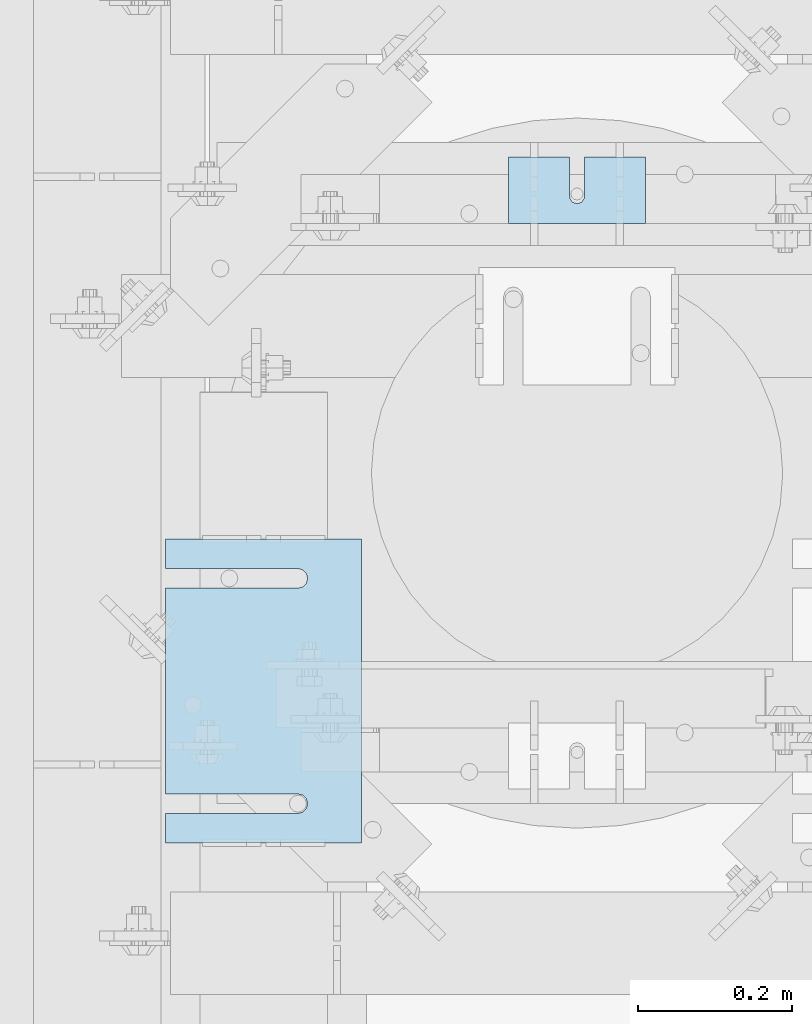
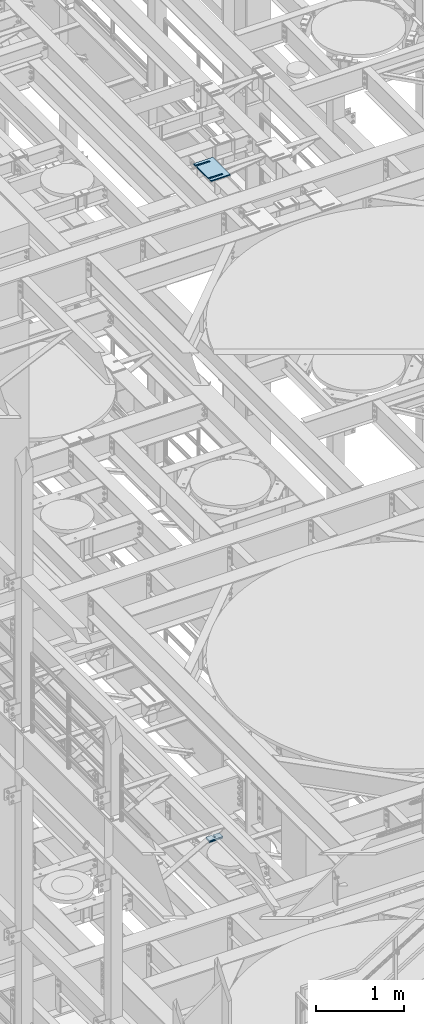
# One storey, part 1636 of 1876: 11 plates, 11 elements without a shape of their own.
"""IFC2X3 building model written with IfcOpenShell, lengths in millimetres."""

from ifc_helpers import new_model, si_unit, frame, origin_with_axes, place, context, subcontext, project, spatial, faceted_brep, material, type_object, element, aggregate, save


model = new_model("IFC2X3")

# Units and contexts
model_context = context("Model", 3, precision=1e-05, world=origin_with_axes())
body_context = subcontext(model_context, "Body", "Model", "MODEL_VIEW")
ifc_project = project(units=[si_unit("LENGTHUNIT", "METRE", prefix="MILLI"), si_unit("AREAUNIT", "SQUARE_METRE"), si_unit("VOLUMEUNIT", "CUBIC_METRE"), si_unit("MASSUNIT", "GRAM", prefix="KILO"), si_unit("TIMEUNIT", "SECOND"), si_unit("PLANEANGLEUNIT", "RADIAN"), si_unit("SOLIDANGLEUNIT", "STERADIAN"), si_unit("THERMODYNAMICTEMPERATUREUNIT", "DEGREE_CELSIUS"), si_unit("LUMINOUSINTENSITYUNIT", "LUMEN")], contexts=[model_context])

# Site, building, storey
site_placement = place(None, origin_with_axes())
site = spatial("IfcSite", under=ifc_project, at=site_placement, CompositionType="ELEMENT")
building_placement = place(site_placement, origin_with_axes())
building = spatial("IfcBuilding", under=site, at=building_placement, Name="Undefined", CompositionType="ELEMENT")
storey_placement = place(building_placement, origin_with_axes())
storey = spatial("IfcBuildingStorey", under=building, at=storey_placement, Name="Undefined", CompositionType="ELEMENT", Elevation=0.0)

# Assembly, plate
assembly_1_placement = place(storey_placement, origin_with_axes())
assembly_1 = element("IfcElementAssembly", 1, at=assembly_1_placement, inside=storey, Name="SHIM PLATE", AssemblyPlace="NOTDEFINED", PredefinedType="RIGID_FRAME")
ifc_material = material(Name="STEEL/A36")
plate_type_1 = type_object("IfcPlateType", PredefinedType="NOTDEFINED")
plate_1_placement = place(assembly_1_placement, frame((4508.50086692662, 2765.42767333984, 8158.1635), z_axis=(0.0, 1.0, 0.0), x_axis=(-1.0, 0.0, 0.0)))
plate_1 = element("IfcPlate", 2, at=plate_1_placement, type_object=plate_type_1, material=ifc_material, Name="SHIM PLATE", context=body_context, shape_type="Brep", body=[
    faceted_brep([(79.3754980174272, -4.76249999999982, 85.7959442138672), (79.3816870943956, -4.76249999999982, 38.1942513122049), (79.3816870943956, 4.76249999999982, 38.1942513122049), (79.3754980174272, 4.76249999999982, 85.7959442138672), (79.5339603115162, -4.76249999999982, 32.1592455981272), (79.5339603115162, 4.76249999999982, 32.1592455981272), (83.1558903074947, -4.76249999999982, 27.3295350264834), (83.1558903074947, 4.76249999999982, 27.3295350264834), (88.9066875296403, -4.76249999999982, 25.4930132021109), (88.9066875296403, 4.76249999999982, 25.4930132021109), (94.6574845388659, -4.76249999999982, 27.3295356932131), (94.6574845388659, 4.76249999999982, 27.3295356932131), (98.2794139749021, -4.76249999999982, 32.1592466847724), (98.2794139749021, 4.76249999999982, 32.1592466847724), (98.4316864923421, -4.76249999999982, 38.1942524165047), (98.4316864923421, 4.76249999999982, 38.1942524165047), (98.4254974155128, -4.76249999999982, 85.7959442138635), (98.4254974155128, 4.76249999999982, 85.7959442138672), (0.0, -4.76249999999982, 0.0), (0.0, -4.76249999999982, 85.7959442138672), (0.0, 4.76249999999982, 85.7959442138672), (0.0, 4.76249999999982, 0.0), (177.800994873047, -4.76249999999982, 0.0), (177.800994873047, 4.76249999999982, 0.0), (177.800994873047, -4.76249999999982, 85.7959442138672), (177.800994873047, 4.76249999999982, 85.7959442138672)], [[[0, 1, 2, 3]], [[4, 5, 2, 1]], [[6, 7, 5, 4]], [[8, 9, 7, 6]], [[10, 11, 9, 8]], [[12, 13, 11, 10]], [[14, 15, 13, 12]], [[16, 17, 15, 14]], [[18, 19, 20, 21]], [[22, 18, 21, 23]], [[24, 22, 23, 25]], [[12, 10, 8, 6, 4, 1, 0, 19, 18, 22, 24, 16, 14]], [[20, 19, 0, 3]], [[25, 23, 21, 20, 3, 2, 5, 7, 9, 11, 13, 15, 17]], [[24, 25, 17, 16]]]),
])
aggregate(assembly_1, [plate_1])

assembly_2_placement = place(storey_placement, origin_with_axes())
assembly_2 = element("IfcElementAssembly", 3, at=assembly_2_placement, inside=storey, Name="SHIM PLATE", AssemblyPlace="NOTDEFINED", PredefinedType="RIGID_FRAME")
plate_type_2 = type_object("IfcPlateType", PredefinedType="NOTDEFINED")
plate_2_placement = place(assembly_2_placement, frame((4508.50086692662, 2765.42767333984, 8179.5935), z_axis=(0.0, 1.0, 0.0), x_axis=(-1.0, 0.0, 0.0)))
plate_2 = element("IfcPlate", 4, at=plate_2_placement, type_object=plate_type_2, material=ifc_material, Name="SHIM PLATE", context=body_context, shape_type="Brep", body=[
    faceted_brep([(79.3754980174272, -0.793499999999767, 85.7959442138672), (79.3816870943956, -0.793499999999767, 38.1942513122049), (79.3816870943956, 0.793499999999767, 38.1942513122049), (79.3754980174272, 0.793499999999767, 85.7959442138672), (79.5339603115162, -0.793499999999767, 32.1592455981272), (79.5339603115162, 0.793499999999767, 32.1592455981272), (83.1558903074947, -0.793499999999767, 27.3295350264834), (83.1558903074947, 0.793499999999767, 27.3295350264834), (88.9066875296403, -0.793499999999767, 25.4930132021109), (88.9066875296403, 0.793499999999767, 25.4930132021109), (94.6574845388659, -0.793499999999767, 27.3295356932131), (94.6574845388659, 0.793499999999767, 27.3295356932131), (98.2794139749021, -0.793499999999767, 32.1592466847724), (98.2794139749021, 0.793499999999767, 32.1592466847724), (98.4316864923421, -0.793499999999767, 38.1942524165047), (98.4316864923421, 0.793499999999767, 38.1942524165047), (98.4254974155128, -0.793499999999767, 85.7959442138635), (98.4254974155128, 0.793499999999767, 85.7959442138672), (9.09494701772928e-13, -0.793499999999767, 0.0), (0.0, -0.793499999999767, 85.7959442138672), (0.0, 0.793499999999767, 85.7959442138672), (9.09494701772928e-13, 0.793499999999767, 0.0), (177.800994873047, -0.793499999999767, 0.0), (177.800994873047, 0.793499999999767, 0.0), (177.800994873047, -0.793499999999767, 85.7959442138672), (177.800994873047, 0.793499999999767, 85.7959442138672)], [[[0, 1, 2, 3]], [[4, 5, 2, 1]], [[6, 7, 5, 4]], [[8, 9, 7, 6]], [[10, 11, 9, 8]], [[12, 13, 11, 10]], [[14, 15, 13, 12]], [[16, 17, 15, 14]], [[18, 19, 20, 21]], [[22, 18, 21, 23]], [[24, 22, 23, 25]], [[12, 10, 8, 6, 4, 1, 0, 19, 18, 22, 24, 16, 14]], [[20, 19, 0, 3]], [[25, 23, 21, 20, 3, 2, 5, 7, 9, 11, 13, 15, 17]], [[24, 25, 17, 16]]]),
])
aggregate(assembly_2, [plate_2])

assembly_3_placement = place(storey_placement, origin_with_axes())
assembly_3 = element("IfcElementAssembly", 5, at=assembly_3_placement, inside=storey, Name="SHIM PLATE", AssemblyPlace="NOTDEFINED", PredefinedType="RIGID_FRAME")
plate_type_3 = type_object("IfcPlateType", PredefinedType="NOTDEFINED")
plate_3_placement = place(assembly_3_placement, frame((4508.50086692662, 2765.42767333984, 8177.2125), z_axis=(0.0, 1.0, 0.0), x_axis=(-1.0, 0.0, 0.0)))
plate_3 = element("IfcPlate", 6, at=plate_3_placement, type_object=plate_type_3, material=ifc_material, Name="SHIM PLATE", context=body_context, shape_type="Brep", body=[
    faceted_brep([(79.3754980174272, -1.58749999999964, 85.7959442138672), (79.3816870943956, -1.58749999999964, 38.1942513122049), (79.3816870943956, 1.58749999999964, 38.1942513122049), (79.3754980174272, 1.58749999999964, 85.7959442138672), (79.5339603115162, -1.58749999999964, 32.1592455981272), (79.5339603115162, 1.58749999999964, 32.1592455981272), (83.1558903074947, -1.58749999999964, 27.3295350264834), (83.1558903074947, 1.58749999999964, 27.3295350264834), (88.9066875296403, -1.58749999999964, 25.4930132021109), (88.9066875296403, 1.58749999999964, 25.4930132021109), (94.6574845388659, -1.58749999999964, 27.3295356932131), (94.6574845388659, 1.58749999999964, 27.3295356932131), (98.2794139749021, -1.58749999999964, 32.1592466847724), (98.2794139749021, 1.58749999999964, 32.1592466847724), (98.4316864923421, -1.58749999999964, 38.1942524165047), (98.4316864923421, 1.58749999999964, 38.1942524165047), (98.4254974155128, -1.58749999999964, 85.7959442138635), (98.4254974155128, 1.58749999999964, 85.7959442138672), (9.09494701772928e-13, -1.58750000000146, 4.54747350886464e-13), (0.0, -1.58749999999964, 85.7959442138672), (0.0, 1.58749999999964, 85.7959442138672), (9.09494701772928e-13, 1.58750000000146, 4.54747350886464e-13), (177.800994873047, -1.58749999999964, 0.0), (177.800994873047, 1.58749999999964, 0.0), (177.800994873047, -1.58749999999964, 85.7959442138672), (177.800994873047, 1.58749999999964, 85.7959442138672)], [[[0, 1, 2, 3]], [[4, 5, 2, 1]], [[6, 7, 5, 4]], [[8, 9, 7, 6]], [[10, 11, 9, 8]], [[12, 13, 11, 10]], [[14, 15, 13, 12]], [[16, 17, 15, 14]], [[18, 19, 20, 21]], [[22, 18, 21, 23]], [[24, 22, 23, 25]], [[12, 10, 8, 6, 4, 1, 0, 19, 18, 22, 24, 16, 14]], [[20, 19, 0, 3]], [[25, 23, 21, 20, 3, 2, 5, 7, 9, 11, 13, 15, 17]], [[24, 25, 17, 16]]]),
])
aggregate(assembly_3, [plate_3])

assembly_4_placement = place(storey_placement, origin_with_axes())
assembly_4 = element("IfcElementAssembly", 7, at=assembly_4_placement, inside=storey, Name="SHIM PLATE", AssemblyPlace="NOTDEFINED", PredefinedType="RIGID_FRAME")
plate_4_placement = place(assembly_4_placement, frame((4508.50086692662, 2765.42767333984, 8174.0375), z_axis=(0.0, 1.0, 0.0), x_axis=(-1.0, 0.0, 0.0)))
plate_4 = element("IfcPlate", 8, at=plate_4_placement, type_object=plate_type_3, material=ifc_material, Name="SHIM PLATE", context=body_context, shape_type="Brep", body=[
    faceted_brep([(79.3754980174272, -1.58749999999964, 85.7959442138672), (79.3816870943956, -1.58749999999964, 38.1942513122049), (79.3816870943956, 1.58749999999964, 38.1942513122049), (79.3754980174272, 1.58749999999964, 85.7959442138672), (79.5339603115162, -1.58749999999964, 32.1592455981272), (79.5339603115162, 1.58749999999964, 32.1592455981272), (83.1558903074947, -1.58749999999964, 27.3295350264834), (83.1558903074947, 1.58749999999964, 27.3295350264834), (88.9066875296403, -1.58749999999964, 25.4930132021109), (88.9066875296403, 1.58749999999964, 25.4930132021109), (94.6574845388659, -1.58749999999964, 27.3295356932131), (94.6574845388659, 1.58749999999964, 27.3295356932131), (98.2794139749021, -1.58749999999964, 32.1592466847724), (98.2794139749021, 1.58749999999964, 32.1592466847724), (98.4316864923421, -1.58749999999964, 38.1942524165047), (98.4316864923421, 1.58749999999964, 38.1942524165047), (98.4254974155128, -1.58749999999964, 85.7959442138635), (98.4254974155128, 1.58749999999964, 85.7959442138672), (9.09494701772928e-13, -1.58750000000146, 4.54747350886464e-13), (0.0, -1.58749999999964, 85.7959442138672), (0.0, 1.58749999999964, 85.7959442138672), (9.09494701772928e-13, 1.58750000000146, 4.54747350886464e-13), (177.800994873047, -1.58749999999964, 0.0), (177.800994873047, 1.58749999999964, 0.0), (177.800994873047, -1.58749999999964, 85.7959442138672), (177.800994873047, 1.58749999999964, 85.7959442138672)], [[[0, 1, 2, 3]], [[4, 5, 2, 1]], [[6, 7, 5, 4]], [[8, 9, 7, 6]], [[10, 11, 9, 8]], [[12, 13, 11, 10]], [[14, 15, 13, 12]], [[16, 17, 15, 14]], [[18, 19, 20, 21]], [[22, 18, 21, 23]], [[24, 22, 23, 25]], [[12, 10, 8, 6, 4, 1, 0, 19, 18, 22, 24, 16, 14]], [[20, 19, 0, 3]], [[25, 23, 21, 20, 3, 2, 5, 7, 9, 11, 13, 15, 17]], [[24, 25, 17, 16]]]),
])
aggregate(assembly_4, [plate_4])

assembly_5_placement = place(storey_placement, origin_with_axes())
assembly_5 = element("IfcElementAssembly", 9, at=assembly_5_placement, inside=storey, Name="SHIM PLATE", AssemblyPlace="NOTDEFINED", PredefinedType="RIGID_FRAME")
plate_type_4 = type_object("IfcPlateType", PredefinedType="NOTDEFINED")
plate_5_placement = place(assembly_5_placement, frame((4508.50086692662, 2765.42767333984, 8170.069), z_axis=(0.0, 1.0, 0.0), x_axis=(-1.0, 0.0, 0.0)))
plate_5 = element("IfcPlate", 10, at=plate_5_placement, type_object=plate_type_4, material=ifc_material, Name="SHIM PLATE", context=body_context, shape_type="Brep", body=[
    faceted_brep([(79.3754980174272, -2.38100000000031, 85.7959442138672), (79.3816870943956, -2.38100000000031, 38.1942513122049), (79.3816870943956, 2.38100000000031, 38.1942513122049), (79.3754980174272, 2.38100000000031, 85.7959442138672), (79.5339603115162, -2.38100000000031, 32.1592455981272), (79.5339603115162, 2.38100000000031, 32.1592455981272), (83.1558903074947, -2.38100000000031, 27.3295350264834), (83.1558903074947, 2.38100000000031, 27.3295350264834), (88.9066875296403, -2.38100000000031, 25.4930132021109), (88.9066875296403, 2.38100000000031, 25.4930132021109), (94.6574845388659, -2.38100000000031, 27.3295356932131), (94.6574845388659, 2.38100000000031, 27.3295356932131), (98.2794139749021, -2.38100000000031, 32.1592466847724), (98.2794139749021, 2.38100000000031, 32.1592466847724), (98.4316864923421, -2.38100000000031, 38.1942524165047), (98.4316864923421, 2.38100000000031, 38.1942524165047), (98.4254974155128, -2.38100000000031, 85.7959442138635), (98.4254974155128, 2.38100000000031, 85.7959442138672), (0.0, -2.38100000000122, 4.54747350886464e-13), (0.0, -2.38100000000031, 85.7959442138672), (0.0, 2.38100000000031, 85.7959442138672), (0.0, 2.38100000000122, 4.54747350886464e-13), (177.800994873047, -2.38100000000031, 0.0), (177.800994873047, 2.38100000000031, 0.0), (177.800994873047, -2.38100000000031, 85.7959442138672), (177.800994873047, 2.38100000000031, 85.7959442138672)], [[[0, 1, 2, 3]], [[4, 5, 2, 1]], [[6, 7, 5, 4]], [[8, 9, 7, 6]], [[10, 11, 9, 8]], [[12, 13, 11, 10]], [[14, 15, 13, 12]], [[16, 17, 15, 14]], [[18, 19, 20, 21]], [[22, 18, 21, 23]], [[24, 22, 23, 25]], [[12, 10, 8, 6, 4, 1, 0, 19, 18, 22, 24, 16, 14]], [[20, 19, 0, 3]], [[25, 23, 21, 20, 3, 2, 5, 7, 9, 11, 13, 15, 17]], [[24, 25, 17, 16]]]),
])
aggregate(assembly_5, [plate_5])

assembly_6_placement = place(storey_placement, origin_with_axes())
assembly_6 = element("IfcElementAssembly", 11, at=assembly_6_placement, inside=storey, Name="SHIM PLATE", AssemblyPlace="NOTDEFINED", PredefinedType="RIGID_FRAME")
plate_6_placement = place(assembly_6_placement, frame((4508.50086692662, 2765.42767333984, 8165.307), z_axis=(0.0, 1.0, 0.0), x_axis=(-1.0, 0.0, 0.0)))
plate_6 = element("IfcPlate", 12, at=plate_6_placement, type_object=plate_type_4, material=ifc_material, Name="SHIM PLATE", context=body_context, shape_type="Brep", body=[
    faceted_brep([(79.3754980174272, -2.38100000000031, 85.7959442138672), (79.3816870943956, -2.38100000000031, 38.1942513122049), (79.3816870943956, 2.38100000000031, 38.1942513122049), (79.3754980174272, 2.38100000000031, 85.7959442138672), (79.5339603115162, -2.38100000000031, 32.1592455981272), (79.5339603115162, 2.38100000000031, 32.1592455981272), (83.1558903074947, -2.38100000000031, 27.3295350264834), (83.1558903074947, 2.38100000000031, 27.3295350264834), (88.9066875296403, -2.38100000000031, 25.4930132021109), (88.9066875296403, 2.38100000000031, 25.4930132021109), (94.6574845388659, -2.38100000000031, 27.3295356932131), (94.6574845388659, 2.38100000000031, 27.3295356932131), (98.2794139749021, -2.38100000000031, 32.1592466847724), (98.2794139749021, 2.38100000000031, 32.1592466847724), (98.4316864923421, -2.38100000000031, 38.1942524165047), (98.4316864923421, 2.38100000000031, 38.1942524165047), (98.4254974155128, -2.38100000000031, 85.7959442138635), (98.4254974155128, 2.38100000000031, 85.7959442138672), (0.0, -2.38100000000122, 4.54747350886464e-13), (0.0, -2.38100000000031, 85.7959442138672), (0.0, 2.38100000000031, 85.7959442138672), (0.0, 2.38100000000122, 4.54747350886464e-13), (177.800994873047, -2.38100000000031, 0.0), (177.800994873047, 2.38100000000031, 0.0), (177.800994873047, -2.38100000000031, 85.7959442138672), (177.800994873047, 2.38100000000031, 85.7959442138672)], [[[0, 1, 2, 3]], [[4, 5, 2, 1]], [[6, 7, 5, 4]], [[8, 9, 7, 6]], [[10, 11, 9, 8]], [[12, 13, 11, 10]], [[14, 15, 13, 12]], [[16, 17, 15, 14]], [[18, 19, 20, 21]], [[22, 18, 21, 23]], [[24, 22, 23, 25]], [[12, 10, 8, 6, 4, 1, 0, 19, 18, 22, 24, 16, 14]], [[20, 19, 0, 3]], [[25, 23, 21, 20, 3, 2, 5, 7, 9, 11, 13, 15, 17]], [[24, 25, 17, 16]]]),
])
aggregate(assembly_6, [plate_6])

assembly_7_placement = place(storey_placement, origin_with_axes())
assembly_7 = element("IfcElementAssembly", 13, at=assembly_7_placement, inside=storey, Name="SHIM PLATE", AssemblyPlace="NOTDEFINED", PredefinedType="RIGID_FRAME")
plate_type_5 = type_object("IfcPlateType", PredefinedType="NOTDEFINED")
plate_7_placement = place(assembly_7_placement, frame((4140.19755067496, 1962.15311651737, 18007.0115), z_axis=(-1.0, 0.0, 0.0), x_axis=(0.0, 1.0, 0.0)))
plate_7 = element("IfcPlate", 14, at=plate_7_placement, type_object=plate_type_5, material=ifc_material, Name="SHIM PLATE", context=body_context, shape_type="Brep", body=[
    faceted_brep([(38.0954210666328, -1.58750000000146, 253.999557495103), (38.0976431969724, -1.58750000000146, 82.6182312417654), (38.0976431969724, 1.58750000000146, 82.6182312417654), (38.0954210666328, 1.58750000000146, 253.999557495103), (39.7991131045027, -1.58750000000146, 76.2682279470096), (39.7991131045027, 1.58750000000146, 76.2682279470096), (44.4476316136985, -1.58750000000146, 71.6196994315187), (44.4476316136985, 1.58750000000146, 71.6196994315187), (50.7976312458977, -1.58750000000146, 69.9182158551362), (50.7976312458977, 1.58750000000146, 69.9182158551362), (57.1476337740625, -1.58750000000146, 71.6196886236189), (57.1476337740625, 1.58750000000146, 71.6196886236189), (61.7961601951824, -1.58750000000146, 76.2682092271793), (61.7961601951824, 1.58750000000146, 76.2682092271793), (63.497640910601, -1.58750000000146, 82.6182096259718), (63.497640910601, 1.58750000000146, 82.6182096259718), (63.4954187799489, -1.58750000000146, 253.999557267866), (63.4954187799489, 1.58750000000146, 253.999557495093), (9.09494701772928e-13, -1.58750000000146, 4.54747350886464e-13), (1.89071320164658e-05, -1.58750000000146, 253.999557495117), (1.89071320164658e-05, 1.58750000000146, 253.999557495117), (9.09494701772928e-13, 1.58750000000146, 4.54747350886464e-13), (393.698486328125, -1.58750000000146, -1.40062184073031e-10), (393.698486328125, 1.58750000000146, -1.40062184073031e-10), (393.698516845714, -1.58750000000146, 253.999557494967), (393.698516845714, 1.58750000000146, 253.999557494967), (355.593905292273, 1.58750000000146, 253.999557494981), (355.593905292273, -1.58750000000146, 253.999558194833), (355.596127251301, 1.58750000000146, 82.6182258117283), (355.596127251301, -1.58750000000146, 82.6182258117283), (353.894652887411, 1.58750000000146, 76.2682211679371), (353.894652887411, -1.58750000000146, 76.2682211679371), (349.246128913514, 1.58750000000146, 71.6196946431969), (349.246128913514, -1.58750000000146, 71.6196946431969), (342.896125203397, 1.58750000000146, 69.9182167947934), (342.896125203397, -1.58750000000146, 69.9182167947934), (336.546122348359, 1.58750000000146, 71.6196978343955), (336.546122348359, -1.58750000000146, 71.6196978343955), (331.897600710579, 1.58750000000146, 76.2682266952543), (331.897600710579, -1.58750000000146, 76.2682266952543), (330.196129537885, 1.58750000000146, 82.6182321941214), (330.196129537885, -1.58750000000146, 82.6182321941214), (330.193907578964, -1.58750000000146, 253.999557494991), (330.193907578964, 1.58750000000146, 253.999557494991)], [[[0, 1, 2, 3]], [[4, 5, 2, 1]], [[6, 7, 5, 4]], [[8, 9, 7, 6]], [[10, 11, 9, 8]], [[12, 13, 11, 10]], [[14, 15, 13, 12]], [[16, 17, 15, 14]], [[18, 19, 20, 21]], [[22, 18, 21, 23]], [[24, 22, 23, 25]], [[24, 25, 26, 27]], [[27, 26, 28, 29]], [[29, 28, 30, 31]], [[31, 30, 32, 33]], [[33, 32, 34, 35]], [[35, 34, 36, 37]], [[37, 36, 38, 39]], [[39, 38, 40, 41]], [[42, 41, 40, 43]], [[12, 10, 8, 6, 4, 1, 0, 19, 18, 22, 24, 27, 29, 31, 33, 35, 37, 39, 41, 42, 16, 14]], [[20, 19, 0, 3]], [[43, 40, 38, 36, 34, 32, 30, 28, 26, 25, 23, 21, 20, 3, 2, 5, 7, 9, 11, 13, 15, 17]], [[42, 43, 17, 16]]]),
])
aggregate(assembly_7, [plate_7])

assembly_8_placement = place(storey_placement, origin_with_axes())
assembly_8 = element("IfcElementAssembly", 15, at=assembly_8_placement, inside=storey, Name="SHIM PLATE", AssemblyPlace="NOTDEFINED", PredefinedType="RIGID_FRAME")
plate_8_placement = place(assembly_8_placement, frame((4140.19755067514, 1962.15311651737, 18003.8365), z_axis=(-1.0, 0.0, 0.0), x_axis=(0.0, 1.0, 0.0)))
plate_8 = element("IfcPlate", 16, at=plate_8_placement, type_object=plate_type_5, material=ifc_material, Name="SHIM PLATE", context=body_context, shape_type="Brep", body=[
    faceted_brep([(38.0954210666328, -1.58750000000146, 253.999557495103), (38.0976431969724, -1.58750000000146, 82.6182312417654), (38.0976431969724, 1.58750000000146, 82.6182312417654), (38.0954210666328, 1.58750000000146, 253.999557495103), (39.7991131045027, -1.58750000000146, 76.2682279470096), (39.7991131045027, 1.58750000000146, 76.2682279470096), (44.4476316136985, -1.58750000000146, 71.6196994315187), (44.4476316136985, 1.58750000000146, 71.6196994315187), (50.7976312458977, -1.58750000000146, 69.9182158551362), (50.7976312458977, 1.58750000000146, 69.9182158551362), (57.1476337740625, -1.58750000000146, 71.6196886236189), (57.1476337740625, 1.58750000000146, 71.6196886236189), (61.7961601951824, -1.58750000000146, 76.2682092271793), (61.7961601951824, 1.58750000000146, 76.2682092271793), (63.497640910601, -1.58750000000146, 82.6182096259718), (63.497640910601, 1.58750000000146, 82.6182096259718), (63.4954187799489, -1.58750000000146, 253.999557267866), (63.4954187799489, 1.58750000000146, 253.999557495093), (9.09494701772928e-13, -1.58750000000146, 4.54747350886464e-13), (1.89071320164658e-05, -1.58750000000146, 253.999557495117), (1.89071320164658e-05, 1.58750000000146, 253.999557495117), (9.09494701772928e-13, 1.58750000000146, 4.54747350886464e-13), (393.698486328125, -1.58750000000146, -1.40062184073031e-10), (393.698486328125, 1.58750000000146, -1.40062184073031e-10), (393.698516845714, -1.58750000000146, 253.999557494967), (393.698516845714, 1.58750000000146, 253.999557494967), (355.593905292273, 1.58750000000146, 253.999557494981), (355.593905292273, -1.58750000000146, 253.999558194833), (355.596127251301, 1.58750000000146, 82.6182258117283), (355.596127251301, -1.58750000000146, 82.6182258117283), (353.894652887411, 1.58750000000146, 76.2682211679371), (353.894652887411, -1.58750000000146, 76.2682211679371), (349.246128913514, 1.58750000000146, 71.6196946431969), (349.246128913514, -1.58750000000146, 71.6196946431969), (342.896125203397, 1.58750000000146, 69.9182167947934), (342.896125203397, -1.58750000000146, 69.9182167947934), (336.546122348359, 1.58750000000146, 71.6196978343955), (336.546122348359, -1.58750000000146, 71.6196978343955), (331.897600710579, 1.58750000000146, 76.2682266952543), (331.897600710579, -1.58750000000146, 76.2682266952543), (330.196129537885, 1.58750000000146, 82.6182321941214), (330.196129537885, -1.58750000000146, 82.6182321941214), (330.193907578964, -1.58750000000146, 253.999557494991), (330.193907578964, 1.58750000000146, 253.999557494991)], [[[0, 1, 2, 3]], [[4, 5, 2, 1]], [[6, 7, 5, 4]], [[8, 9, 7, 6]], [[10, 11, 9, 8]], [[12, 13, 11, 10]], [[14, 15, 13, 12]], [[16, 17, 15, 14]], [[18, 19, 20, 21]], [[22, 18, 21, 23]], [[24, 22, 23, 25]], [[24, 25, 26, 27]], [[27, 26, 28, 29]], [[29, 28, 30, 31]], [[31, 30, 32, 33]], [[33, 32, 34, 35]], [[35, 34, 36, 37]], [[37, 36, 38, 39]], [[39, 38, 40, 41]], [[42, 41, 40, 43]], [[12, 10, 8, 6, 4, 1, 0, 19, 18, 22, 24, 27, 29, 31, 33, 35, 37, 39, 41, 42, 16, 14]], [[20, 19, 0, 3]], [[43, 40, 38, 36, 34, 32, 30, 28, 26, 25, 23, 21, 20, 3, 2, 5, 7, 9, 11, 13, 15, 17]], [[42, 43, 17, 16]]]),
])
aggregate(assembly_8, [plate_8])

assembly_9_placement = place(storey_placement, origin_with_axes())
assembly_9 = element("IfcElementAssembly", 17, at=assembly_9_placement, inside=storey, Name="SHIM PLATE", AssemblyPlace="NOTDEFINED", PredefinedType="RIGID_FRAME")
plate_type_6 = type_object("IfcPlateType", PredefinedType="NOTDEFINED")
plate_9_placement = place(assembly_9_placement, frame((4140.19755067479, 1962.15311651737, 18009.3925), z_axis=(-1.0, 0.0, 0.0), x_axis=(0.0, 1.0, 0.0)))
plate_9 = element("IfcPlate", 18, at=plate_9_placement, type_object=plate_type_6, material=ifc_material, Name="SHIM PLATE", context=body_context, shape_type="Brep", body=[
    faceted_brep([(38.0954210666328, -0.793499999999767, 253.999557495103), (38.0976431969724, -0.793499999999767, 82.6182312417654), (38.0976431969724, 0.793499999999767, 82.6182312417654), (38.0954210666328, 0.793499999999767, 253.999557495103), (39.7991131045027, -0.793499999999767, 76.2682279470096), (39.7991131045027, 0.793499999999767, 76.2682279470096), (44.4476316136985, -0.793499999999767, 71.6196994315187), (44.4476316136985, 0.793499999999767, 71.6196994315187), (50.7976312458977, -0.793499999999767, 69.9182158551362), (50.7976312458977, 0.793499999999767, 69.9182158551362), (57.1476337740625, -0.793499999999767, 71.6196886236189), (57.1476337740625, 0.793499999999767, 71.6196886236189), (61.7961601951824, -0.793499999999767, 76.2682092271793), (61.7961601951824, 0.793499999999767, 76.2682092271793), (63.497640910601, -0.793499999999767, 82.6182096259718), (63.497640910601, 0.793499999999767, 82.6182096259718), (63.4954187799489, -0.793499999999767, 253.999557267866), (63.4954187799489, 0.793499999999767, 253.999557495093), (9.09494701772928e-13, -0.793499999999767, 0.0), (1.89070156011439e-05, -0.793499999999767, 253.999557495117), (1.89070156011439e-05, 0.793499999999767, 253.999557495117), (9.09494701772928e-13, 0.793499999999767, 0.0), (393.698486328125, -0.793499999999767, -1.39152689371258e-10), (393.698486328125, 0.793499999999767, -1.39152689371258e-10), (393.698516845714, -0.793499999999767, 253.999557494967), (393.698516845714, 0.793499999999767, 253.999557494967), (355.593905292273, 0.793499999999767, 253.999557494981), (355.593905292273, -0.793499999999767, 253.999558194833), (355.596127251301, 0.793499999999767, 82.6182258117283), (355.596127251301, -0.793499999999767, 82.6182258117283), (353.894652887411, 0.793499999999767, 76.2682211679371), (353.894652887411, -0.793499999999767, 76.2682211679371), (349.246128913514, 0.793499999999767, 71.6196946431969), (349.246128913514, -0.793499999999767, 71.6196946431969), (342.896125203397, 0.793499999999767, 69.9182167947934), (342.896125203397, -0.793499999999767, 69.9182167947934), (336.546122348359, 0.793499999999767, 71.6196978343955), (336.546122348359, -0.793499999999767, 71.6196978343955), (331.897600710579, 0.793499999999767, 76.2682266952543), (331.897600710579, -0.793499999999767, 76.2682266952543), (330.196129537885, 0.793499999999767, 82.6182321941214), (330.196129537885, -0.793499999999767, 82.6182321941214), (330.193907578964, -0.793499999999767, 253.999557494991), (330.193907578964, 0.793499999999767, 253.999557494991)], [[[0, 1, 2, 3]], [[4, 5, 2, 1]], [[6, 7, 5, 4]], [[8, 9, 7, 6]], [[10, 11, 9, 8]], [[12, 13, 11, 10]], [[14, 15, 13, 12]], [[16, 17, 15, 14]], [[18, 19, 20, 21]], [[22, 18, 21, 23]], [[24, 22, 23, 25]], [[24, 25, 26, 27]], [[27, 26, 28, 29]], [[29, 28, 30, 31]], [[31, 30, 32, 33]], [[33, 32, 34, 35]], [[35, 34, 36, 37]], [[37, 36, 38, 39]], [[39, 38, 40, 41]], [[42, 41, 40, 43]], [[12, 10, 8, 6, 4, 1, 0, 19, 18, 22, 24, 27, 29, 31, 33, 35, 37, 39, 41, 42, 16, 14]], [[20, 19, 0, 3]], [[43, 40, 38, 36, 34, 32, 30, 28, 26, 25, 23, 21, 20, 3, 2, 5, 7, 9, 11, 13, 15, 17]], [[42, 43, 17, 16]]]),
])
aggregate(assembly_9, [plate_9])

assembly_10_placement = place(storey_placement, origin_with_axes())
assembly_10 = element("IfcElementAssembly", 19, at=assembly_10_placement, inside=storey, Name="SHIM PLATE", AssemblyPlace="NOTDEFINED", PredefinedType="RIGID_FRAME")
plate_type_7 = type_object("IfcPlateType", PredefinedType="NOTDEFINED")
plate_10_placement = place(assembly_10_placement, frame((4140.19755067532, 1962.15311651737, 17999.868), z_axis=(-1.0, 0.0, 0.0), x_axis=(0.0, 1.0, 0.0)))
plate_10 = element("IfcPlate", 20, at=plate_10_placement, type_object=plate_type_7, material=ifc_material, Name="SHIM PLATE", context=body_context, shape_type="Brep", body=[
    faceted_brep([(38.0954210666329, -2.38100000000122, 253.999557495103), (38.0976431969724, -2.38100000000122, 82.6182312417654), (38.0976431969724, 2.38100000000122, 82.6182312417654), (38.0954210666329, 2.38100000000122, 253.999557495103), (39.7991131045027, -2.38100000000122, 76.2682279470096), (39.7991131045027, 2.38100000000122, 76.2682279470096), (44.4476316136985, -2.38100000000122, 71.6196994315187), (44.4476316136985, 2.38100000000122, 71.6196994315187), (50.7976312458977, -2.38100000000122, 69.9182158551362), (50.7976312458977, 2.38100000000122, 69.9182158551362), (57.1476337740625, -2.38100000000122, 71.6196886236189), (57.1476337740625, 2.38100000000122, 71.6196886236189), (61.7961601951824, -2.38100000000122, 76.2682092271793), (61.7961601951824, 2.38100000000122, 76.2682092271793), (63.497640910601, -2.38100000000122, 82.6182096259718), (63.497640910601, 2.38100000000122, 82.6182096259718), (63.4954187799489, -2.38100000000122, 253.999557267866), (63.4954187799489, 2.38100000000122, 253.999557495093), (0.0, -2.38100000000122, 4.54747350886464e-13), (1.89072484317876e-05, -2.38100000000122, 253.999557495117), (1.89072484317876e-05, 2.38100000000122, 253.999557495117), (0.0, 2.38100000000122, 4.54747350886464e-13), (393.698486328125, -2.38100000000122, -1.40971678774804e-10), (393.698486328125, 2.38100000000122, -1.40971678774804e-10), (393.698516845714, -2.38100000000122, 253.999557494967), (393.698516845714, 2.38100000000122, 253.999557494967), (355.593905292273, 2.38100000000122, 253.999557494981), (355.593905292273, -2.38100000000122, 253.999558194833), (355.596127251301, 2.38100000000122, 82.6182258117283), (355.596127251301, -2.38100000000122, 82.6182258117283), (353.894652887411, 2.38100000000122, 76.2682211679371), (353.894652887411, -2.38100000000122, 76.2682211679371), (349.246128913514, 2.38100000000122, 71.6196946431969), (349.246128913514, -2.38100000000122, 71.6196946431969), (342.896125203397, 2.38100000000122, 69.9182167947934), (342.896125203397, -2.38100000000122, 69.9182167947934), (336.546122348359, 2.38100000000122, 71.6196978343955), (336.546122348359, -2.38100000000122, 71.6196978343955), (331.897600710579, 2.38100000000122, 76.2682266952543), (331.897600710579, -2.38100000000122, 76.2682266952543), (330.196129537885, 2.38100000000122, 82.6182321941214), (330.196129537885, -2.38100000000122, 82.6182321941214), (330.193907578964, -2.38100000000122, 253.999557494991), (330.193907578964, 2.38100000000122, 253.999557494991)], [[[0, 1, 2, 3]], [[4, 5, 2, 1]], [[6, 7, 5, 4]], [[8, 9, 7, 6]], [[10, 11, 9, 8]], [[12, 13, 11, 10]], [[14, 15, 13, 12]], [[16, 17, 15, 14]], [[18, 19, 20, 21]], [[22, 18, 21, 23]], [[24, 22, 23, 25]], [[24, 25, 26, 27]], [[27, 26, 28, 29]], [[29, 28, 30, 31]], [[31, 30, 32, 33]], [[33, 32, 34, 35]], [[35, 34, 36, 37]], [[37, 36, 38, 39]], [[39, 38, 40, 41]], [[42, 41, 40, 43]], [[12, 10, 8, 6, 4, 1, 0, 19, 18, 22, 24, 27, 29, 31, 33, 35, 37, 39, 41, 42, 16, 14]], [[20, 19, 0, 3]], [[43, 40, 38, 36, 34, 32, 30, 28, 26, 25, 23, 21, 20, 3, 2, 5, 7, 9, 11, 13, 15, 17]], [[42, 43, 17, 16]]]),
])
aggregate(assembly_10, [plate_10])

assembly_11_placement = place(storey_placement, origin_with_axes())
assembly_11 = element("IfcElementAssembly", 21, at=assembly_11_placement, inside=storey, Name="SHIM PLATE", AssemblyPlace="NOTDEFINED", PredefinedType="RIGID_FRAME")
plate_11_placement = place(assembly_11_placement, frame((4140.1975506755, 1962.15311651737, 17995.106), z_axis=(-1.0, 0.0, 0.0), x_axis=(0.0, 1.0, 0.0)))
plate_11 = element("IfcPlate", 22, at=plate_11_placement, type_object=plate_type_7, material=ifc_material, Name="SHIM PLATE", context=body_context, shape_type="Brep", body=[
    faceted_brep([(38.0954210666329, -2.38100000000122, 253.999557495103), (38.0976431969724, -2.38100000000122, 82.6182312417654), (38.0976431969724, 2.38100000000122, 82.6182312417654), (38.0954210666329, 2.38100000000122, 253.999557495103), (39.7991131045027, -2.38100000000122, 76.2682279470096), (39.7991131045027, 2.38100000000122, 76.2682279470096), (44.4476316136985, -2.38100000000122, 71.6196994315187), (44.4476316136985, 2.38100000000122, 71.6196994315187), (50.7976312458977, -2.38100000000122, 69.9182158551362), (50.7976312458977, 2.38100000000122, 69.9182158551362), (57.1476337740625, -2.38100000000122, 71.6196886236189), (57.1476337740625, 2.38100000000122, 71.6196886236189), (61.7961601951824, -2.38100000000122, 76.2682092271793), (61.7961601951824, 2.38100000000122, 76.2682092271793), (63.497640910601, -2.38100000000122, 82.6182096259718), (63.497640910601, 2.38100000000122, 82.6182096259718), (63.4954187799489, -2.38100000000122, 253.999557267866), (63.4954187799489, 2.38100000000122, 253.999557495093), (0.0, -2.38100000000122, 4.54747350886464e-13), (1.89072484317876e-05, -2.38100000000122, 253.999557495117), (1.89072484317876e-05, 2.38100000000122, 253.999557495117), (0.0, 2.38100000000122, 4.54747350886464e-13), (393.698486328125, -2.38100000000122, -1.40971678774804e-10), (393.698486328125, 2.38100000000122, -1.40971678774804e-10), (393.698516845714, -2.38100000000122, 253.999557494967), (393.698516845714, 2.38100000000122, 253.999557494967), (355.593905292273, 2.38100000000122, 253.999557494981), (355.593905292273, -2.38100000000122, 253.999558194833), (355.596127251301, 2.38100000000122, 82.6182258117283), (355.596127251301, -2.38100000000122, 82.6182258117283), (353.894652887411, 2.38100000000122, 76.2682211679371), (353.894652887411, -2.38100000000122, 76.2682211679371), (349.246128913514, 2.38100000000122, 71.6196946431969), (349.246128913514, -2.38100000000122, 71.6196946431969), (342.896125203397, 2.38100000000122, 69.9182167947934), (342.896125203397, -2.38100000000122, 69.9182167947934), (336.546122348359, 2.38100000000122, 71.6196978343955), (336.546122348359, -2.38100000000122, 71.6196978343955), (331.897600710579, 2.38100000000122, 76.2682266952543), (331.897600710579, -2.38100000000122, 76.2682266952543), (330.196129537885, 2.38100000000122, 82.6182321941214), (330.196129537885, -2.38100000000122, 82.6182321941214), (330.193907578964, -2.38100000000122, 253.999557494991), (330.193907578964, 2.38100000000122, 253.999557494991)], [[[0, 1, 2, 3]], [[4, 5, 2, 1]], [[6, 7, 5, 4]], [[8, 9, 7, 6]], [[10, 11, 9, 8]], [[12, 13, 11, 10]], [[14, 15, 13, 12]], [[16, 17, 15, 14]], [[18, 19, 20, 21]], [[22, 18, 21, 23]], [[24, 22, 23, 25]], [[24, 25, 26, 27]], [[27, 26, 28, 29]], [[29, 28, 30, 31]], [[31, 30, 32, 33]], [[33, 32, 34, 35]], [[35, 34, 36, 37]], [[37, 36, 38, 39]], [[39, 38, 40, 41]], [[42, 41, 40, 43]], [[12, 10, 8, 6, 4, 1, 0, 19, 18, 22, 24, 27, 29, 31, 33, 35, 37, 39, 41, 42, 16, 14]], [[20, 19, 0, 3]], [[43, 40, 38, 36, 34, 32, 30, 28, 26, 25, 23, 21, 20, 3, 2, 5, 7, 9, 11, 13, 15, 17]], [[42, 43, 17, 16]]]),
])
aggregate(assembly_11, [plate_11])

save(model, "model.ifc")
